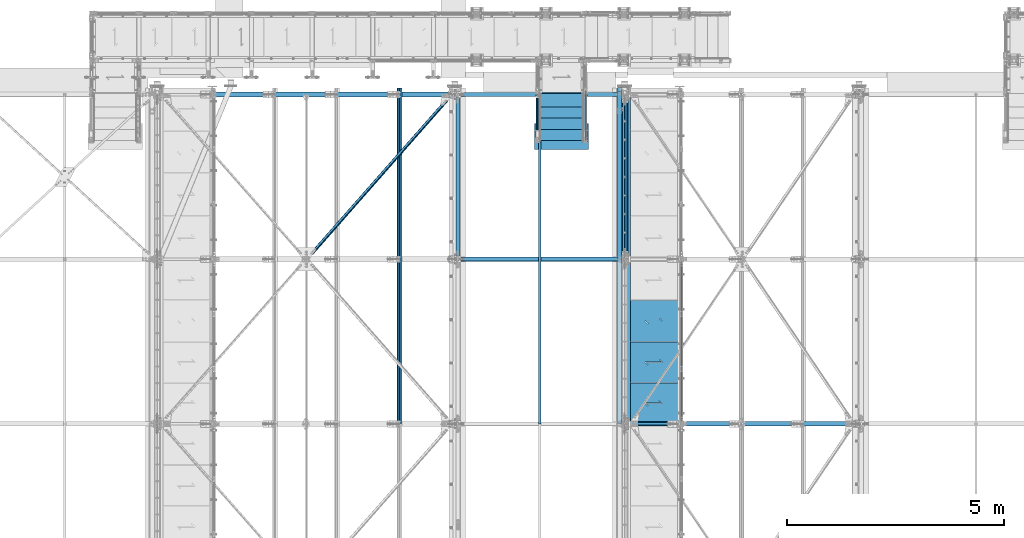
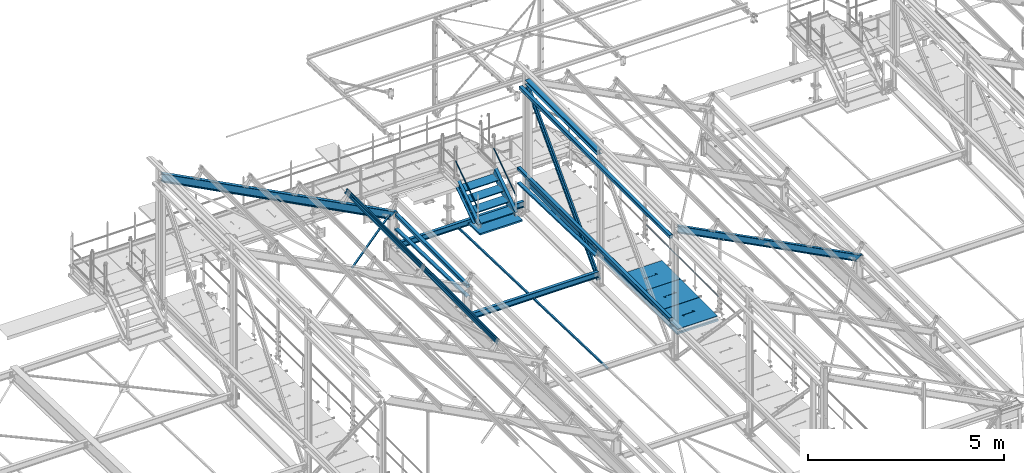
# One storey, part 50 of 496: 22 beams, 8 members, 30 elements without a shape of their own.
"""IFC2X3 building model written with IfcOpenShell, lengths in millimetres."""

from ifc_helpers import new_model, si_unit, frame, origin_with_axes, origin_2d_with_axis, place, context, subcontext, project, spatial, polyline, rectangle, hollow_rectangle, hollow_circle, i_section, l_section, u_section, outline, extrude, boolean, clip, halfspace, material, type_object, element, aggregate, save


model = new_model("IFC2X3")

# Units and contexts
model_context = context("Model", 3, precision=1e-05, world=origin_with_axes())
body_context = subcontext(model_context, "Body", "Model", "MODEL_VIEW")
ifc_project = project(units=[si_unit("LENGTHUNIT", "METRE", prefix="MILLI"), si_unit("AREAUNIT", "SQUARE_METRE"), si_unit("VOLUMEUNIT", "CUBIC_METRE"), si_unit("MASSUNIT", "GRAM", prefix="KILO"), si_unit("TIMEUNIT", "SECOND"), si_unit("PLANEANGLEUNIT", "RADIAN"), si_unit("SOLIDANGLEUNIT", "STERADIAN"), si_unit("THERMODYNAMICTEMPERATUREUNIT", "DEGREE_CELSIUS"), si_unit("LUMINOUSINTENSITYUNIT", "LUMEN")], contexts=[model_context])

# Site, building, storey
site_placement = place(None, origin_with_axes())
site = spatial("IfcSite", under=ifc_project, at=site_placement, CompositionType="ELEMENT")
building_placement = place(site_placement, origin_with_axes())
building = spatial("IfcBuilding", under=site, at=building_placement, Name="Undefined", CompositionType="ELEMENT")
storey_placement = place(building_placement, origin_with_axes())
storey = spatial("IfcBuildingStorey", under=building, at=storey_placement, Name="Undefined", CompositionType="ELEMENT", Elevation=0.0)

# Assembly, member
assembly_1_placement = place(storey_placement, origin_with_axes())
assembly_1 = element("IfcElementAssembly", 1, at=assembly_1_placement, inside=storey, Name="MAIN COURANTE", AssemblyPlace="NOTDEFINED", PredefinedType="NOTDEFINED")
ifc_material_1 = material(Name="Undefined/S235-E24")
member_type_1 = type_object("IfcMemberType", PredefinedType="NOTDEFINED")
member_1_placement = place(assembly_1_placement, frame((22569.9936634988, 14144.9998536997, 8651.13839395851), z_axis=(0.999999999999672, -6.66011674184119e-07, -4.61008081401814e-07), x_axis=(0.0, 0.822192191679776, 0.569209978778312)))
member_1 = element("IfcMember", 2, at=member_1_placement, type_object=member_type_1, material=ifc_material_1, Name="LISSE", context=body_context, shape_type="Clipping", body=[
    clip(clip(extrude(hollow_circle(Radius=10.64999962, WallThickness=2.0, at=origin_2d_with_axis()), frame((1395.35433691202, -1.13686837721616e-12, 7.38694435286663e-20), z_axis=(-1.0, 0.0, 0.0), x_axis=(0.0, -1.0, 0.0)), (0.0, 0.0, 1.0), 1404.17), halfspace(frame((1387.78549896895, 10.5802584847568, -0.00112410556903342), z_axis=(-0.822192191679508, 0.569209978778309, 6.66011673795452e-07), x_axis=(-0.569209978778123, -0.822192191679778, 4.61008086858783e-07)), True)), halfspace(frame((16.4615054726892, 14.9935154708171, -1.33328576339409e-05), z_axis=(0.822192191679509, -0.569209978778308, -6.66011673277761e-07), x_axis=(0.0, 0.0, -1.0)), True)),
])
aggregate(assembly_1, [member_1])

assembly_2_placement = place(storey_placement, origin_with_axes())
assembly_2 = element("IfcElementAssembly", 3, at=assembly_2_placement, inside=storey, Name="MAIN COURANTE", AssemblyPlace="NOTDEFINED", PredefinedType="NOTDEFINED")
member_2_placement = place(assembly_2_placement, frame((21449.9863365012, 14144.9998536997, 8651.13839395851), z_axis=(-0.999999999999672, -6.66011674184119e-07, -4.61008081401814e-07), x_axis=(0.0, 0.822192191679776, 0.569209978778312)))
member_2 = element("IfcMember", 4, at=member_2_placement, type_object=member_type_1, material=ifc_material_1, Name="LISSE", context=body_context, shape_type="Clipping", body=[
    clip(clip(extrude(hollow_circle(Radius=10.64999962, WallThickness=2.0, at=origin_2d_with_axis()), frame((1395.35433691202, -1.13686837721616e-12, 7.38694435286663e-20), z_axis=(-1.0, 0.0, 0.0), x_axis=(0.0, -1.0, 0.0)), (0.0, 0.0, 1.0), 1404.17), halfspace(frame((1387.78549896895, -10.5802584847571, -0.00112410556539544), z_axis=(-0.822192191679501, -0.569209978778319, 6.66011673795446e-07), x_axis=(0.0, 0.0, -1.0)), True)), halfspace(frame((16.4615054726892, -14.9935154708165, -1.33328503579833e-05), z_axis=(0.822192191679509, 0.569209978778308, -6.6601167379545e-07), x_axis=(-0.569209978778121, 0.822192191679779, 4.61008079582826e-07)), True)),
])
aggregate(assembly_2, [member_2])

# Assembly, beam
assembly_3_placement = place(storey_placement, origin_with_axes())
assembly_3 = element("IfcElementAssembly", 5, at=assembly_3_placement, inside=storey, AssemblyPlace="NOTDEFINED", PredefinedType="NOTDEFINED")
beam_type_1 = type_object("IfcBeamType", PredefinedType="NOTDEFINED")
beam_1_placement = place(assembly_3_placement, frame((21507.0000126664, 7601.38524277558, 7606.01559960975), z_axis=(1.0, 0.0, 0.0), x_axis=(0.0, 0.999506556345274, -0.0314108870109058)))
beam_1 = element("IfcBeam", 6, at=beam_1_placement, type_object=beam_type_1, material=ifc_material_1, context=body_context, shape_type="SweptSolid", body=[
    extrude(l_section(Depth=50.0, Width=50.0, Thickness=5.0, FilletRadius=7.0, EdgeRadius=3.5, at=origin_2d_with_axis()), frame((7644.25203515468, 5.30426538466652e-14, 0.0), z_axis=(-1.0, 0.0, 0.0), x_axis=(0.0, -1.0, 0.0)), (0.0, 0.0, 1.0), 7644.25),
])
aggregate(assembly_3, [beam_1])

# Assembly, member
assembly_4_placement = place(storey_placement, origin_with_axes())
assembly_4 = element("IfcElementAssembly", 7, at=assembly_4_placement, inside=storey, AssemblyPlace="NOTDEFINED", PredefinedType="NOTDEFINED")
ifc_material_2 = material(Name="Undefined/S275-E28")
member_type_2 = type_object("IfcMemberType", Name="UPN260", PredefinedType="NOTDEFINED")
member_3_placement = place(assembly_4_placement, frame((22554.9957050653, 15220.1081967775, 8803.11488296132), z_axis=(-2.38199999876088e-06, 0.569209978780056, -0.822192191675118), x_axis=(-8.09999997507615e-07, -0.822192191679509, -0.569209978778121)))
member_3 = element("IfcMember", 8, at=member_3_placement, type_object=member_type_2, material=ifc_material_2, ObjectType="UPN260", context=body_context, shape_type="Clipping", body=[
    clip(clip(clip(extrude(u_section(Depth=260.0, FlangeWidth=90.0, WebThickness=10.0, FlangeThickness=14.0, FilletRadius=14.0, EdgeRadius=7.0, FlangeSlope=0.0798299857122373, at=origin_2d_with_axis()), frame((1532.05974941516, 3.24426271229202e-19, 1.50656932765752e-12), z_axis=(-1.0, 0.0, 0.0), x_axis=(0.0, -1.0, 0.0)), (0.0, 0.0, 1.0), 1652.65), halfspace(frame((1475.10561376755, -44.9999999999982, -130.0), z_axis=(0.594754891759256, -2.93590080272386e-06, 0.803907095826263), x_axis=(-0.803907095829728, -3.97667463540568e-10, 0.594754891761819)), False)), halfspace(frame((1280.85769771495, 106.407624448384, -129.999853684547), z_axis=(-0.822192191678566, 5.58458236969981e-08, 0.569209978780058), x_axis=(0.569209978777471, -2.93579533354204e-06, 0.822192191675117)), True)), halfspace(frame((81.2187427422505, 545.001446996483, 130.001191003446), z_axis=(0.954513538741863, -9.28664575673263e-07, -0.298167577643218), x_axis=(1.71699999918928e-06, 0.999999999995689, 2.38199999876088e-06)), True)),
])
aggregate(assembly_4, [member_3])

assembly_5_placement = place(storey_placement, origin_with_axes())
assembly_5 = element("IfcElementAssembly", 9, at=assembly_5_placement, inside=storey, AssemblyPlace="NOTDEFINED", PredefinedType="NOTDEFINED")
member_4_placement = place(assembly_5_placement, frame((21465.0064946267, 14166.9970857892, 8074.0379599759), z_axis=(2.38199999876088e-06, 0.569209978780056, -0.822192191675118), x_axis=(-1.7169999996433e-06, 0.822192191678566, 0.56920997877747)))
member_4 = element("IfcMember", 10, at=member_4_placement, type_object=member_type_2, material=ifc_material_2, ObjectType="UPN260", context=body_context, shape_type="Clipping", body=[
    clip(clip(clip(extrude(u_section(Depth=260.0, FlangeWidth=90.0, WebThickness=10.0, FlangeThickness=14.0, FilletRadius=14.0, EdgeRadius=7.0, FlangeSlope=0.0798299857122373, at=origin_2d_with_axis()), frame((1401.450854294, -1.81898940354586e-12, 2.27373675443232e-13), z_axis=(-1.0, 0.0, 0.0), x_axis=(0.0, -1.0, 0.0)), (0.0, 0.0, 1.0), 1652.65), halfspace(frame((-194.248465676397, 44.9999999999982, -130.0), z_axis=(-0.594754891759256, -2.93590079459986e-06, 0.803907095826263), x_axis=(0.803907095829729, -3.97667463540568e-10, 0.594754891761818)), False)), halfspace(frame((1199.63884956697, 544.98906444852, 130.001190898261), z_axis=(-0.954513538741863, -9.28664579145766e-07, -0.298167577643217), x_axis=(1.71700000282726e-06, -0.999999999995689, -2.38199999876088e-06)), True)), halfspace(frame((-0.000105426983282086, 106.407623989038, -129.999853760241), z_axis=(0.822192191678561, 5.58458236969708e-08, 0.569209978780065), x_axis=(1.71700000282726e-06, -0.999999999995689, -2.38199999876088e-06)), True)),
])
aggregate(assembly_5, [member_4])

# Assembly, beam
assembly_6_placement = place(storey_placement, origin_with_axes())
assembly_6 = element("IfcElementAssembly", 11, at=assembly_6_placement, inside=storey, Name="Steel Assembly", AssemblyPlace="NOTDEFINED", PredefinedType="NOTDEFINED")
ifc_material_3 = material(Name="POLYURETHANE")
beam_type_2 = type_object("IfcBeamType", PredefinedType="NOTDEFINED")
beam_2_placement = place(assembly_6_placement, frame((22009.9947340707, 14532.1706378134, 7968.49328384745), z_axis=(-1.0, 0.0, 0.0), x_axis=(0.0, -0.999506556345276, 0.031410887010852)))
beam_2 = element("IfcBeam", 12, at=beam_2_placement, type_object=beam_type_2, material=ifc_material_3, context=body_context, shape_type="SweptSolid", body=[
    extrude(rectangle(XDim=50.0, YDim=1250.0, at=origin_2d_with_axis()), frame((600.000000000075, -4.16333634234486e-15, 0.0), z_axis=(-1.0, 0.0, 0.0), x_axis=(0.0, -1.0, 0.0)), (0.0, 0.0, 1.0), 600.0),
])
aggregate(assembly_6, [beam_2])

assembly_7_placement = place(storey_placement, origin_with_axes())
assembly_7 = element("IfcElementAssembly", 13, at=assembly_7_placement, inside=storey, Name="MARCHE", AssemblyPlace="NOTDEFINED", PredefinedType="NOTDEFINED")
beam_type_3 = type_object("IfcBeamType", PredefinedType="NOTDEFINED")
beam_3_placement = place(assembly_7_placement, frame((22009.9938089558, 14444.9997910501, 8145.0000000973), z_axis=(-1.0, 0.0, 0.0), x_axis=(0.0, -1.0, 0.0)))
beam_3 = element("IfcBeam", 14, at=beam_3_placement, type_object=beam_type_3, material=ifc_material_1, Name="MARCHE", context=body_context, shape_type="SweptSolid", body=[
    extrude(rectangle(XDim=30.0, YDim=994.0, at=origin_2d_with_axis()), frame((310.0, 0.0, 0.0), z_axis=(-1.0, 0.0, 0.0), x_axis=(0.0, -1.0, 0.0)), (0.0, 0.0, 1.0), 310.0),
])
aggregate(assembly_7, [beam_3])

assembly_8_placement = place(storey_placement, origin_with_axes())
assembly_8 = element("IfcElementAssembly", 15, at=assembly_8_placement, inside=storey, Name="MARCHE", AssemblyPlace="NOTDEFINED", PredefinedType="NOTDEFINED")
beam_4_placement = place(assembly_8_placement, frame((22009.9938089558, 14704.9997910501, 8325.00000007297), z_axis=(-1.0, 0.0, 0.0), x_axis=(0.0, -1.0, 0.0)))
beam_4 = element("IfcBeam", 16, at=beam_4_placement, type_object=beam_type_3, material=ifc_material_1, Name="MARCHE", context=body_context, shape_type="SweptSolid", body=[
    extrude(rectangle(XDim=30.0, YDim=994.0, at=origin_2d_with_axis()), frame((310.0, 0.0, 0.0), z_axis=(-1.0, 0.0, 0.0), x_axis=(0.0, -1.0, 0.0)), (0.0, 0.0, 1.0), 310.0),
])
aggregate(assembly_8, [beam_4])

assembly_9_placement = place(storey_placement, origin_with_axes())
assembly_9 = element("IfcElementAssembly", 17, at=assembly_9_placement, inside=storey, Name="MARCHE", AssemblyPlace="NOTDEFINED", PredefinedType="NOTDEFINED")
beam_5_placement = place(assembly_9_placement, frame((22009.9938089558, 14964.9997910501, 8505.00000004865), z_axis=(-1.0, 0.0, 0.0), x_axis=(0.0, -1.0, 0.0)))
beam_5 = element("IfcBeam", 18, at=beam_5_placement, type_object=beam_type_3, material=ifc_material_1, Name="MARCHE", context=body_context, shape_type="SweptSolid", body=[
    extrude(rectangle(XDim=30.0, YDim=994.0, at=origin_2d_with_axis()), frame((310.0, 0.0, 0.0), z_axis=(-1.0, 0.0, 0.0), x_axis=(0.0, -1.0, 0.0)), (0.0, 0.0, 1.0), 310.0),
])
aggregate(assembly_9, [beam_5])

assembly_10_placement = place(storey_placement, origin_with_axes())
assembly_10 = element("IfcElementAssembly", 19, at=assembly_10_placement, inside=storey, Name="MARCHE", AssemblyPlace="NOTDEFINED", PredefinedType="NOTDEFINED")
beam_6_placement = place(assembly_10_placement, frame((22009.9938089558, 15224.9997910501, 8685.0), z_axis=(-1.0, 0.0, 0.0), x_axis=(0.0, -1.0, 0.0)))
beam_6 = element("IfcBeam", 20, at=beam_6_placement, type_object=beam_type_3, material=ifc_material_1, Name="MARCHE", context=body_context, shape_type="SweptSolid", body=[
    extrude(rectangle(XDim=30.0, YDim=994.0, at=origin_2d_with_axis()), frame((310.0, 0.0, 0.0), z_axis=(-1.0, 0.0, 0.0), x_axis=(0.0, -1.0, 0.0)), (0.0, 0.0, 1.0), 310.0),
])
aggregate(assembly_10, [beam_6])

assembly_11_placement = place(storey_placement, origin_with_axes())
assembly_11 = element("IfcElementAssembly", 21, at=assembly_11_placement, inside=storey, AssemblyPlace="NOTDEFINED", PredefinedType="NOTDEFINED")
beam_type_4 = type_object("IfcBeamType", PredefinedType="NOTDEFINED")
beam_7_placement = place(assembly_11_placement, frame((16130.7913108013, 11397.8852377669, 10299.8650291357), z_axis=(-0.628485335729624, 0.704921087892877, 0.328774151381682), x_axis=(0.62461790718323, 0.709285739208058, -0.32675099109585)))
beam_7 = element("IfcBeam", 22, at=beam_7_placement, type_object=beam_type_4, material=ifc_material_1, context=body_context, shape_type="Clipping", body=[
    clip(clip(extrude(l_section(Depth=60.0, Width=60.0, Thickness=6.0, FilletRadius=8.0, EdgeRadius=4.0, at=origin_2d_with_axis()), frame((5278.55482785582, 0.0, -3.15847707165208e-13), z_axis=(-1.0, 0.0, 0.0), x_axis=(0.0, -1.0, 0.0)), (0.0, 0.0, 1.0), 5199.61), halfspace(frame((5188.72425075795, 30.0000249835939, 30.0000008168934), z_axis=(-1.0, 0.0, 0.0), x_axis=(0.0, -1.0, 0.0)), True)), halfspace(frame((168.778198553695, 30.0000021388769, -29.999999220274), z_axis=(1.0, 0.0, 0.0), x_axis=(0.0, -1.0, 0.0)), True)),
])
aggregate(assembly_11, [beam_7])

assembly_12_placement = place(storey_placement, origin_with_axes())
assembly_12 = element("IfcElementAssembly", 23, at=assembly_12_placement, inside=storey, Name="LISSE", AssemblyPlace="NOTDEFINED", PredefinedType="NOTDEFINED")
beam_type_5 = type_object("IfcBeamType", PredefinedType="NOTDEFINED")
beam_8_placement = place(assembly_12_placement, frame((23353.5001162926, 11402.9585391484, 8171.89575101457), z_axis=(1.0, 0.0, 0.0), x_axis=(0.0, 0.999506445341009, -0.0314144190107172)))
beam_8 = element("IfcBeam", 24, at=beam_8_placement, type_object=beam_type_5, material=ifc_material_1, Name="LISSE", context=body_context, shape_type="Clipping", body=[
    clip(extrude(u_section(Depth=100.0, FlangeWidth=50.0, WebThickness=4.0, FlangeThickness=4.0, at=origin_2d_with_axis()), frame((3989.01014791664, 0.0, 0.0), z_axis=(-1.0, 0.0, 0.0), x_axis=(0.0, -1.0, 0.0)), (0.0, 0.0, 1.0), 3989.01), halfspace(frame((3959.78106204689, -24.99999999994, -50.0), z_axis=(0.999506472307554, 0.0314135610096964, 0.0), x_axis=(0.0, 0.0, 1.0)), False)),
])
aggregate(assembly_12, [beam_8])

assembly_13_placement = place(storey_placement, origin_with_axes())
assembly_13 = element("IfcElementAssembly", 25, at=assembly_13_placement, inside=storey, Name="LISSE", AssemblyPlace="NOTDEFINED", PredefinedType="NOTDEFINED")
beam_9_placement = place(assembly_13_placement, frame((19620.0000000142, 11400.0, 8171.98873515491), z_axis=(1.0, 0.0, 0.0), x_axis=(0.0, 0.999506445341009, -0.0314144190107172)))
beam_9 = element("IfcBeam", 26, at=beam_9_placement, type_object=beam_type_5, material=ifc_material_1, Name="LISSE", context=body_context, shape_type="Clipping", body=[
    clip(clip(extrude(u_section(Depth=100.0, FlangeWidth=50.0, WebThickness=4.0, FlangeThickness=4.0, at=origin_2d_with_axis()), frame((3738.43140425554, 0.0, 0.0), z_axis=(-1.0, 0.0, 0.0), x_axis=(0.0, -1.0, 0.0)), (0.0, 0.0, 1.0), 3674.99), halfspace(frame((3734.02168286743, 89.8070816101499, 49.9999999858046), z_axis=(-0.999506472307554, -0.0314135610096736, 0.0), x_axis=(0.0, 0.0, 1.0)), True)), halfspace(frame((63.1144992302961, 61.0134432793748, 49.9999999858046), z_axis=(-0.999506472307554, -0.0314135610096736, 0.0), x_axis=(0.0, 0.0, 1.0)), False)),
])
aggregate(assembly_13, [beam_9])

assembly_14_placement = place(storey_placement, origin_with_axes())
assembly_14 = element("IfcElementAssembly", 27, at=assembly_14_placement, inside=storey, Name="LISSE", AssemblyPlace="NOTDEFINED", PredefinedType="NOTDEFINED")
beam_type_6 = type_object("IfcBeamType", PredefinedType="NOTDEFINED")
beam_10_placement = place(assembly_14_placement, frame((23353.5000011002, 7604.99999901568, 11069.999999999), z_axis=(0.0, 0.0, -1.0), x_axis=(0.0, 1.0, 0.0)))
beam_10 = element("IfcBeam", 28, at=beam_10_placement, type_object=beam_type_6, material=ifc_material_1, Name="LISSE", context=body_context, shape_type="SweptSolid", body=[
    extrude(hollow_rectangle(XDim=100.0, YDim=100.0, WallThickness=4.0, InnerFilletRadius=4.0, OuterFilletRadius=8.0, at=origin_2d_with_axis()), frame((7664.99999999271, 0.0, 0.0), z_axis=(-1.0, 0.0, 0.0), x_axis=(0.0, -1.0, 0.0)), (0.0, 0.0, 1.0), 7665.0),
])
aggregate(assembly_14, [beam_10])

assembly_15_placement = place(storey_placement, origin_with_axes())
assembly_15 = element("IfcElementAssembly", 29, at=assembly_15_placement, inside=storey, Name="LISSE", AssemblyPlace="NOTDEFINED", PredefinedType="NOTDEFINED")
beam_11_placement = place(assembly_15_placement, frame((23353.5, 7605.0, 8500.0), z_axis=(0.0, 0.0, 1.0), x_axis=(0.0, 1.0, 0.0)))
beam_11 = element("IfcBeam", 30, at=beam_11_placement, type_object=beam_type_6, material=ifc_material_1, Name="LISSE", context=body_context, shape_type="SweptSolid", body=[
    extrude(hollow_rectangle(XDim=100.0, YDim=100.0, WallThickness=4.0, InnerFilletRadius=4.0, OuterFilletRadius=8.0, at=origin_2d_with_axis()), frame((7755.0, 0.0, 0.0), z_axis=(-1.0, 0.0, 0.0), x_axis=(0.0, -1.0, 0.0)), (0.0, 0.0, 1.0), 7755.0),
])
aggregate(assembly_15, [beam_11])

assembly_16_placement = place(storey_placement, origin_with_axes())
assembly_16 = element("IfcElementAssembly", 31, at=assembly_16_placement, inside=storey, Name="LISSE", AssemblyPlace="NOTDEFINED", PredefinedType="NOTDEFINED")
beam_12_placement = place(assembly_16_placement, frame((19619.9999999823, 11470.0, 8500.0), z_axis=(0.0, 0.0, 1.0), x_axis=(0.0, 1.0, 0.0)))
beam_12 = element("IfcBeam", 32, at=beam_12_placement, type_object=beam_type_6, material=ifc_material_1, Name="LISSE", context=body_context, shape_type="SweptSolid", body=[
    extrude(hollow_rectangle(XDim=100.0, YDim=100.0, WallThickness=4.0, InnerFilletRadius=4.0, OuterFilletRadius=8.0, at=origin_2d_with_axis()), frame((3660.0, 0.0, 0.0), z_axis=(-1.0, 0.0, 0.0), x_axis=(0.0, -1.0, 0.0)), (0.0, 0.0, 1.0), 3660.0),
])
aggregate(assembly_16, [beam_12])

assembly_17_placement = place(storey_placement, origin_with_axes())
assembly_17 = element("IfcElementAssembly", 33, at=assembly_17_placement, inside=storey, AssemblyPlace="NOTDEFINED", PredefinedType="NOTDEFINED")
beam_type_7 = type_object("IfcBeamType", PredefinedType="NOTDEFINED")
beam_13_placement = place(assembly_17_placement, frame((24726.4915934611, 8545.00015707402, 8115.0), z_axis=(0.0, 0.0, 1.0), x_axis=(-1.0, 0.0, 0.0)))
beam_13 = element("IfcBeam", 34, at=beam_13_placement, type_object=beam_type_7, material=ifc_material_1, context=body_context, shape_type="CSG", body=[
    boolean("DIFFERENCE", extrude(outline(polyline([(0.0, 0.0), (1179.99169921875, 0.0), (1179.99169921875, 940.0), (-9.39995516091585e-07, 940.0), (0.0, 0.0)])), frame((0.0, 0.0, -15.0), z_axis=(0.0, 0.0, 1.0), x_axis=(1.0, 0.0, 0.0)), (0.0, 0.0, 1.0), 30.0), extrude(outline(polyline([(0.0, 0.0), (9.99999999997453, 6.91215973347425e-11), (10.0000000004329, 75.8578643791443), (282.842712400121, -196.984848017997), (282.842712400743, -96.9848480190813), (272.842712400776, -96.9848480191613), (272.842712400299, -172.842712398218), (0.0, 100.0), (0.0, 0.0)])), frame((724.286946489367, 535.710676888644, -17.5), z_axis=(0.0, 0.0, 1.0), x_axis=(-0.707106781186457, -0.707106781186639, 0.0)), (0.0, 0.0, 1.0), 35.0)),
])
aggregate(assembly_17, [beam_13])

assembly_18_placement = place(storey_placement, origin_with_axes())
assembly_18 = element("IfcElementAssembly", 35, at=assembly_18_placement, inside=storey, AssemblyPlace="NOTDEFINED", PredefinedType="NOTDEFINED")
beam_14_placement = place(assembly_18_placement, frame((24726.4915991611, 9495.00015707402, 8115.0), z_axis=(0.0, 0.0, 1.0), x_axis=(-1.0, 0.0, 0.0)))
beam_14 = element("IfcBeam", 36, at=beam_14_placement, type_object=beam_type_7, material=ifc_material_1, context=body_context, shape_type="CSG", body=[
    boolean("DIFFERENCE", extrude(outline(polyline([(0.0, 0.0), (1179.99169921875, 0.0), (1179.99169921875, 940.0), (-9.39995516091585e-07, 940.0), (0.0, 0.0)])), frame((0.0, 0.0, -15.0), z_axis=(0.0, 0.0, 1.0), x_axis=(1.0, 0.0, 0.0)), (0.0, 0.0, 1.0), 30.0), extrude(outline(polyline([(0.0, 0.0), (9.99999999997453, 6.91215973347425e-11), (10.0000000004329, 75.8578643791443), (282.842712400121, -196.984848017997), (282.842712400743, -96.9848480190813), (272.842712400776, -96.9848480191613), (272.842712400299, -172.842712398218), (0.0, 100.0), (0.0, 0.0)])), frame((724.286946489367, 535.710676888644, -17.5), z_axis=(0.0, 0.0, 1.0), x_axis=(-0.707106781186457, -0.707106781186639, 0.0)), (0.0, 0.0, 1.0), 35.0)),
])
aggregate(assembly_18, [beam_14])

assembly_19_placement = place(storey_placement, origin_with_axes())
assembly_19 = element("IfcElementAssembly", 37, at=assembly_19_placement, inside=storey, AssemblyPlace="NOTDEFINED", PredefinedType="NOTDEFINED")
beam_15_placement = place(assembly_19_placement, frame((24726.4916048611, 10445.000157074, 8115.0), z_axis=(0.0, 0.0, 1.0), x_axis=(-1.0, 0.0, 0.0)))
beam_15 = element("IfcBeam", 38, at=beam_15_placement, type_object=beam_type_7, material=ifc_material_1, context=body_context, shape_type="CSG", body=[
    boolean("DIFFERENCE", extrude(outline(polyline([(0.0, 0.0), (1179.99169921875, 0.0), (1179.99169921875, 940.0), (-9.39995516091585e-07, 940.0), (0.0, 0.0)])), frame((0.0, 0.0, -15.0), z_axis=(0.0, 0.0, 1.0), x_axis=(1.0, 0.0, 0.0)), (0.0, 0.0, 1.0), 30.0), extrude(outline(polyline([(0.0, 0.0), (9.99999999997453, 6.91215973347425e-11), (10.0000000004329, 75.8578643791443), (282.842712400121, -196.984848017997), (282.842712400743, -96.9848480190813), (272.842712400776, -96.9848480191613), (272.842712400299, -172.842712398218), (0.0, 100.0), (0.0, 0.0)])), frame((724.286946489367, 535.710676888644, -17.5), z_axis=(0.0, 0.0, 1.0), x_axis=(-0.707106781186457, -0.707106781186639, 0.0)), (0.0, 0.0, 1.0), 35.0)),
])
aggregate(assembly_19, [beam_15])

assembly_20_placement = place(storey_placement, origin_with_axes())
assembly_20 = element("IfcElementAssembly", 39, at=assembly_20_placement, inside=storey, Name="MAIN COURANTE", AssemblyPlace="NOTDEFINED", PredefinedType="NOTDEFINED")
beam_type_8 = type_object("IfcBeamType", PredefinedType="NOTDEFINED")
beam_16_placement = place(assembly_20_placement, frame((24783.9916060442, 11345.0000018375, 8673.79999937495), z_axis=(0.0, 0.0, 1.0), x_axis=(0.0, -1.0, 0.0)))
beam_16 = element("IfcBeam", 40, at=beam_16_placement, type_object=beam_type_8, material=ifc_material_1, Name="LISSE", context=body_context, shape_type="SweptSolid", body=[
    extrude(hollow_circle(Radius=13.44999981, WallThickness=2.0, at=origin_2d_with_axis()), frame((3690.00000000169, 3.69000323827281e-24, 0.0), z_axis=(-1.0, 0.0, 0.0), x_axis=(0.0, -1.0, 0.0)), (0.0, 0.0, 1.0), 3690.0),
])
aggregate(assembly_20, [beam_16])

assembly_21_placement = place(storey_placement, origin_with_axes())
assembly_21 = element("IfcElementAssembly", 41, at=assembly_21_placement, inside=storey, AssemblyPlace="NOTDEFINED", PredefinedType="NOTDEFINED")
beam_type_9 = type_object("IfcBeamType", Name="HEA140", PredefinedType="NOTDEFINED")
beam_17_placement = place(assembly_21_placement, frame((23473.5, 15125.0, 11302.5), z_axis=(0.0, 0.0, 1.0), x_axis=(0.0, -1.0, 0.0)))
beam_17 = element("IfcBeam", 42, at=beam_17_placement, type_object=beam_type_9, material=ifc_material_2, ObjectType="HEA140", context=body_context, shape_type="SweptSolid", body=[
    extrude(i_section(OverallWidth=140.0, OverallDepth=133.0, WebThickness=5.5, FlangeThickness=8.5, FilletRadius=12.0, at=origin_2d_with_axis()), frame((3650.0, 0.0, 0.0), z_axis=(-1.0, 0.0, 0.0), x_axis=(0.0, -1.0, 0.0)), (0.0, 0.0, 1.0), 3650.0),
])
aggregate(assembly_21, [beam_17])

assembly_22_placement = place(storey_placement, origin_with_axes())
assembly_22 = element("IfcElementAssembly", 43, at=assembly_22_placement, inside=storey, AssemblyPlace="NOTDEFINED", PredefinedType="NOTDEFINED")
beam_type_10 = type_object("IfcBeamType", PredefinedType="NOTDEFINED")
beam_18_placement = place(assembly_22_placement, frame((23571.499943885, 7605.00000239662, 8025.0), z_axis=(0.0, 0.0, 1.0), x_axis=(0.0, 1.0, 0.0)))
beam_18 = element("IfcBeam", 44, at=beam_18_placement, type_object=beam_type_10, material=ifc_material_1, context=body_context, shape_type="SweptSolid", body=[
    extrude(u_section(Depth=150.0, FlangeWidth=70.0, WebThickness=5.0, FlangeThickness=5.0, at=origin_2d_with_axis()), frame((7755.0000786442, 0.0, 0.0), z_axis=(-1.0, 0.0, 0.0), x_axis=(0.0, -1.0, 0.0)), (0.0, 0.0, 1.0), 7755.0),
])
aggregate(assembly_22, [beam_18])

assembly_23_placement = place(storey_placement, origin_with_axes())
assembly_23 = element("IfcElementAssembly", 45, at=assembly_23_placement, inside=storey, Name="SHED", AssemblyPlace="NOTDEFINED", PredefinedType="NOTDEFINED")
beam_type_11 = type_object("IfcBeamType", PredefinedType="NOTDEFINED")
beam_19_placement = place(assembly_23_placement, frame((18270.8856638494, 7605.00007961586, 9575.33349769386), z_axis=(0.46352885499701, 6.99999093634976e-09, 0.886081824994261), x_axis=(0.0, 1.0, 0.0)))
beam_19 = element("IfcBeam", 46, at=beam_19_placement, type_object=beam_type_11, material=ifc_material_1, Name="SHED", context=body_context, shape_type="SweptSolid", body=[
    extrude(outline(polyline([(-27.9999999860338, 36.0000000101354), (-27.999999986052, 70.0000000101354), (28.0000000138389, 70.0000000101209), (28.0000000138425, 58.0000000101209), (26.5000000138534, 58.0000000101209), (26.5000000138352, 68.5000000101172), (-26.4999999860593, 68.5000000101354), (-26.4999999860338, 36.7000007730749), (-1.49999998607018, 15.6999998194005), (-1.49999998605563, -15.6999997991297), (-26.4999999859974, -36.7000007527895), (-26.4999999859829, -68.49999998985), (26.5000000139153, -68.4999999898646), (26.500000013908, -57.9999999898646), (28.0000000139116, -57.9999999898646), (28.0000000139153, -69.9999999898646), (-27.9999999859756, -69.99999998985), (-27.9999999859901, -35.99999998985), (-2.99999998605927, -14.9999999898646), (-2.9999999860629, 15.0000000101354), (-27.9999999860338, 36.0000000101354)])), frame((7750.00000000006, -3.63797880548905e-12, 0.0), z_axis=(-1.0, 0.0, 0.0), x_axis=(0.0, -1.0, 0.0)), (0.0, 0.0, 1.0), 7750.0),
])
aggregate(assembly_23, [beam_19])

# Assembly, member
assembly_24_placement = place(storey_placement, origin_with_axes())
assembly_24 = element("IfcElementAssembly", 47, at=assembly_24_placement, inside=storey, AssemblyPlace="NOTDEFINED", PredefinedType="NOTDEFINED")
member_type_3 = type_object("IfcMemberType", Name="UPN80", PredefinedType="NOTDEFINED")
member_5_placement = place(assembly_24_placement, frame((23497.5000000297, 11400.0000000125, 7249.99999999999), z_axis=(0.0, -0.723792360031621, 0.690017840030138), x_axis=(0.0, 0.690017837983532, 0.723792361982726)))
member_5 = element("IfcMember", 48, at=member_5_placement, type_object=member_type_3, material=ifc_material_2, ObjectType="UPN80", context=body_context, shape_type="Clipping", body=[
    clip(clip(extrude(u_section(Depth=80.0, FlangeWidth=45.0, WebThickness=6.0, FlangeThickness=8.0, FilletRadius=8.0, EdgeRadius=4.0, FlangeSlope=0.0798299857122373, at=origin_2d_with_axis()), frame((5467.81196900541, 0.0, 0.0), z_axis=(-1.0, 0.0, 0.0), x_axis=(0.0, -1.0, 0.0)), (0.0, 0.0, 1.0), 5428.52), halfspace(frame((5387.10413923787, 27.5000000297259, 39.9999976635263), z_axis=(1.0, 0.0, 0.0), x_axis=(0.0, 1.0, 0.0)), False)), halfspace(frame((119.999999997919, 27.49999999375, -39.9999989691296), z_axis=(-1.0, 0.0, 0.0), x_axis=(0.0, 1.0, 0.0)), False)),
])
aggregate(assembly_24, [member_5])

assembly_25_placement = place(storey_placement, origin_with_axes())
assembly_25 = element("IfcElementAssembly", 49, at=assembly_25_placement, inside=storey, AssemblyPlace="NOTDEFINED", PredefinedType="NOTDEFINED")
member_6_placement = place(assembly_25_placement, frame((23442.5000000316, 15200.0000003585, 11235.9999997217), z_axis=(0.0, -0.723792360031621, 0.690017840030138), x_axis=(0.0, -0.690017840030137, -0.723792360031622)))
member_6 = element("IfcMember", 50, at=member_6_placement, type_object=member_type_3, material=ifc_material_2, ObjectType="UPN80", context=body_context, shape_type="Clipping", body=[
    clip(clip(extrude(u_section(Depth=80.0, FlangeWidth=45.0, WebThickness=6.0, FlangeThickness=8.0, FilletRadius=8.0, EdgeRadius=4.0, FlangeSlope=0.0798299857122373, at=origin_2d_with_axis()), frame((5467.81196900541, 0.0, 0.0), z_axis=(-1.0, 0.0, 0.0), x_axis=(0.0, -1.0, 0.0)), (0.0, 0.0, 1.0), 5428.52), halfspace(frame((5387.10413924701, 27.4999999683605, -40.0000000000014), z_axis=(1.0, 0.0, 0.0), x_axis=(0.0, -1.0, 0.0)), False)), halfspace(frame((119.999999989826, 27.5000000297296, 39.9999985196016), z_axis=(-1.0, 0.0, 0.0), x_axis=(0.0, -1.0, 0.0)), False)),
])
aggregate(assembly_25, [member_6])

# Assembly, beam
assembly_26_placement = place(storey_placement, origin_with_axes())
assembly_26 = element("IfcElementAssembly", 51, at=assembly_26_placement, inside=storey, AssemblyPlace="NOTDEFINED", PredefinedType="NOTDEFINED")
beam_type_12 = type_object("IfcBeamType", PredefinedType="NOTDEFINED")
beam_20_placement = place(assembly_26_placement, frame((23547.9918295866, 7600.0, 8015.0), z_axis=(0.0, -1.0, 0.0), x_axis=(1.0, 0.0, 0.0)))
beam_20 = element("IfcBeam", 52, at=beam_20_placement, type_object=beam_type_12, material=ifc_material_1, context=body_context, shape_type="SweptSolid", body=[
    extrude(hollow_rectangle(XDim=60.0, YDim=60.0, WallThickness=3.0, InnerFilletRadius=3.0, OuterFilletRadius=6.0, at=origin_2d_with_axis()), frame((1181.99977105896, 0.0, 0.0), z_axis=(-1.0, 0.0, 0.0), x_axis=(0.0, -1.0, 0.0)), (0.0, 0.0, 1.0), 1182.0),
])
aggregate(assembly_26, [beam_20])

# Assembly, member
assembly_27_placement = place(storey_placement, origin_with_axes())
assembly_27 = element("IfcElementAssembly", 53, at=assembly_27_placement, inside=storey, Name="TRAVERSE SHED", AssemblyPlace="NOTDEFINED", PredefinedType="NOTDEFINED")
member_type_4 = type_object("IfcMemberType", Name="IPE200", PredefinedType="NOTDEFINED")
member_7_placement = place(assembly_27_placement, frame((23493.9906758698, 7599.99999999682, 11280.2129396085), z_axis=(0.460093364927087, 0.0, 0.887870539859315), x_axis=(0.887870604061616, 0.0, -0.460093241031926)))
member_7 = element("IfcMember", 54, at=member_7_placement, type_object=member_type_4, material=ifc_material_2, Name="TRAVERSE SHED", ObjectType="IPE200", context=body_context, shape_type="Clipping", body=[
    clip(clip(extrude(i_section(OverallWidth=100.0, OverallDepth=200.0, WebThickness=5.599999905, FlangeThickness=8.5, FilletRadius=12.0, at=origin_2d_with_axis()), frame((6236.48041099405, -1.81898940354586e-12, 0.0), z_axis=(-1.0, 0.0, 0.0), x_axis=(0.0, -1.0, 0.0)), (0.0, 0.0, 1.0), 6347.61), halfspace(frame((6005.40058860125, -3799.99999999682, -99.9999999999964), z_axis=(0.854427655127558, 0.0, -0.519570382290236), x_axis=(0.0, -1.0, 0.0)), False)), halfspace(frame((5.77115893586233, 3.18409305520223e-09, 102.990606066072), z_axis=(-0.887870604061619, 0.0, -0.46009324103192), x_axis=(0.0, -1.0, 0.0)), False)),
])
aggregate(assembly_27, [member_7])

assembly_28_placement = place(storey_placement, origin_with_axes())
assembly_28 = element("IfcElementAssembly", 55, at=assembly_28_placement, inside=storey, Name="TRAVERSE SHED", AssemblyPlace="NOTDEFINED", PredefinedType="NOTDEFINED")
member_type_5 = type_object("IfcMemberType", Name="IPE240", PredefinedType="NOTDEFINED")
member_8_placement = place(assembly_28_placement, frame((12694.3765846431, 15199.9999999968, 12063.6701562877), z_axis=(0.46352885499701, 6.99999093634976e-09, 0.886081824994261), x_axis=(0.886081856298361, 3.500000375794e-08, -0.463528795156082)))
member_8 = element("IfcMember", 56, at=member_8_placement, type_object=member_type_5, material=ifc_material_2, Name="TRAVERSE SHED", ObjectType="IPE240", context=body_context, shape_type="Clipping", body=[
    clip(clip(extrude(i_section(OverallWidth=120.0, OverallDepth=240.0, WebThickness=6.199999809, FlangeThickness=9.800000191, FilletRadius=15.0, at=origin_2d_with_axis()), frame((7941.81660004671, -4.54747350886464e-13, 4.40859382336107e-13), z_axis=(-1.0, 0.0, 0.0), x_axis=(0.0, -1.0, 0.0)), (0.0, 0.0, 1.0), 8076.52), halfspace(frame((7809.66068490162, -11399.9999999968, 119.999998325799), z_axis=(-0.855432184782403, 0.0, 0.51791483589332), x_axis=(0.0, -1.0, 0.0)), True)), halfspace(frame((5.75953323153499, 3.18157252429281e-09, 123.012934996157), z_axis=(-0.886082031080585, 0.0, -0.463528461042152), x_axis=(0.0, -1.0, 0.0)), False)),
])
aggregate(assembly_28, [member_8])

# Assembly, beam
assembly_29_placement = place(storey_placement, origin_with_axes())
assembly_29 = element("IfcElementAssembly", 57, at=assembly_29_placement, inside=storey, AssemblyPlace="NOTDEFINED", PredefinedType="NOTDEFINED")
beam_type_13 = type_object("IfcBeamType", Name="IPE180", PredefinedType="NOTDEFINED")
beam_21_placement = place(assembly_29_placement, frame((19659.9999991865, 15199.9999999878, 7482.27624345416), z_axis=(0.0, 0.031410887010906, 0.999506556345274), x_axis=(1.0, 0.0, 0.0)))
beam_21 = element("IfcBeam", 58, at=beam_21_placement, type_object=beam_type_13, material=ifc_material_2, ObjectType="IPE180", context=body_context, shape_type="SweptSolid", body=[
    extrude(i_section(OverallWidth=91.0, OverallDepth=180.0, WebThickness=5.300000191, FlangeThickness=8.0, FilletRadius=9.0, at=origin_2d_with_axis()), frame((3733.49999999622, 0.0, 0.0), z_axis=(-1.0, 0.0, 0.0), x_axis=(0.0, -1.0, 0.0)), (0.0, 0.0, 1.0), 3733.5),
])
aggregate(assembly_29, [beam_21])

assembly_30_placement = place(storey_placement, origin_with_axes())
assembly_30 = element("IfcElementAssembly", 59, at=assembly_30_placement, inside=storey, AssemblyPlace="NOTDEFINED", PredefinedType="NOTDEFINED")
beam_22_placement = place(assembly_30_placement, frame((19659.9999999984, 11399.9999999867, 7601.69607317498), z_axis=(0.0, 0.031410887010906, 0.999506556345274), x_axis=(1.0, 0.0, 0.0)))
beam_22 = element("IfcBeam", 60, at=beam_22_placement, type_object=beam_type_13, material=ifc_material_2, ObjectType="IPE180", context=body_context, shape_type="SweptSolid", body=[
    extrude(i_section(OverallWidth=91.0, OverallDepth=180.0, WebThickness=5.300000191, FlangeThickness=8.0, FilletRadius=9.0, at=origin_2d_with_axis()), frame((3733.49999999622, 0.0, 0.0), z_axis=(-1.0, 0.0, 0.0), x_axis=(0.0, -1.0, 0.0)), (0.0, 0.0, 1.0), 3733.5),
])
aggregate(assembly_30, [beam_22])

save(model, "model.ifc")
